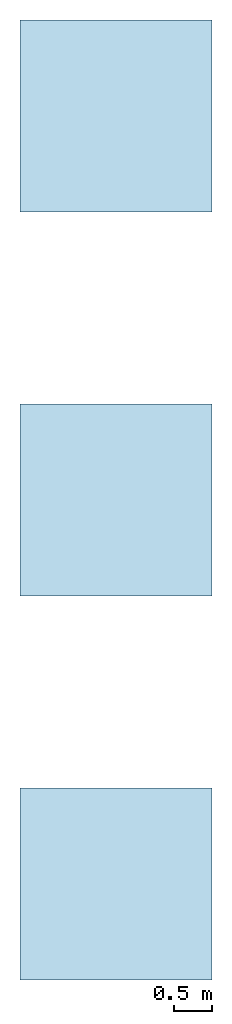
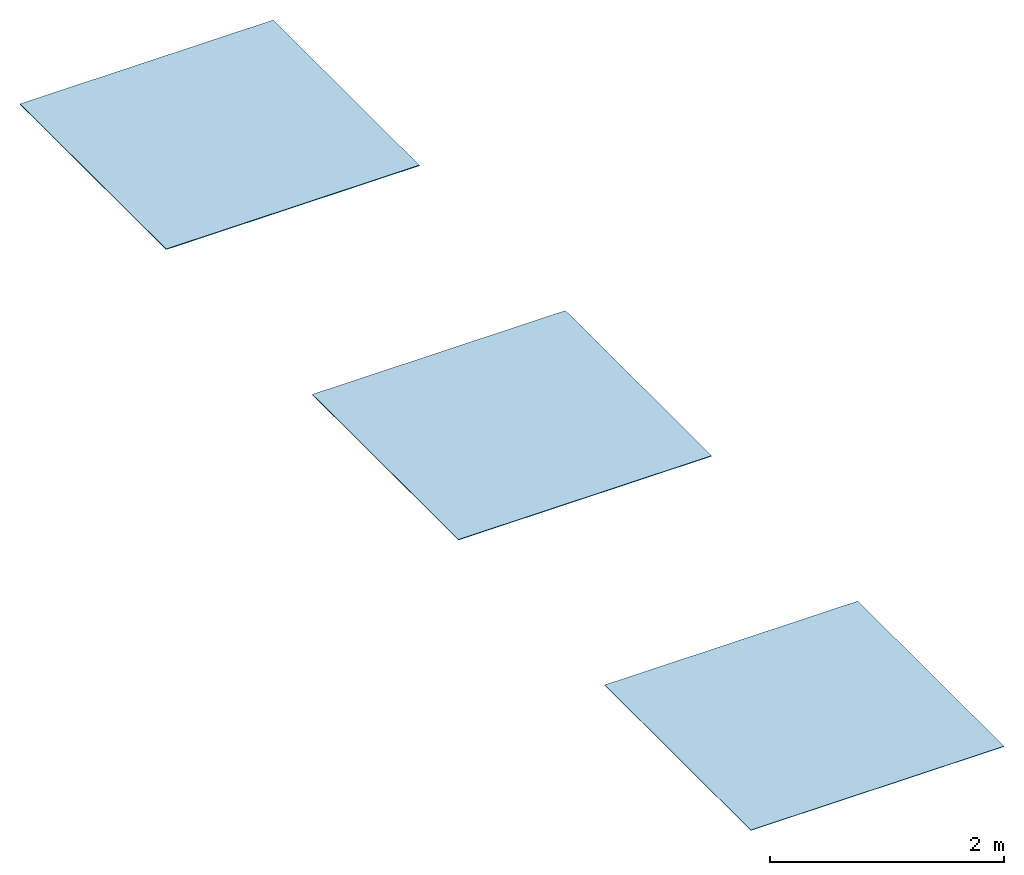
# Not in any storey: 3 slabs.
"""IFC2X3 building model written with IfcOpenShell, lengths in millimetres."""

from ifc_helpers import new_model, si_unit, frame, frame_2d, origin, origin_with_axes, origin_2d, place, context, project, spatial, rectangle, extrude, material, layer, layer_set, layer_usage, type_object, element, save


model = new_model("IFC2X3")

# Units and contexts
model_context = context("Model", 3, precision=1e-05, world=origin())
plan_context = context("Plan", 2, precision=1e-05, world=origin_2d())
ifc_project = project(units=[si_unit("LENGTHUNIT", "METRE", prefix="MILLI"), si_unit("AREAUNIT", "SQUARE_METRE"), si_unit("VOLUMEUNIT", "CUBIC_METRE"), si_unit("SOLIDANGLEUNIT", "STERADIAN"), si_unit("PLANEANGLEUNIT", "RADIAN"), si_unit("MASSUNIT", "GRAM"), si_unit("TIMEUNIT", "SECOND"), si_unit("THERMODYNAMICTEMPERATUREUNIT", "DEGREE_CELSIUS"), si_unit("LUMINOUSINTENSITYUNIT", "LUMEN")], contexts=[model_context, plan_context])

# Site, building
site_placement = place(None, frame((0.0, 0.0, 0.0), z_axis=(0.0, 1.0, 0.0), x_axis=(0.0, 0.0, 1.0)))
site = spatial("IfcSite", under=ifc_project, at=site_placement, CompositionType="ELEMENT")
building_placement = place(site_placement, frame((0.0, 0.0, 0.0), z_axis=(0.0, 1.0, 0.0), x_axis=(0.0, 0.0, 1.0)))
building = spatial("IfcBuilding", under=site, at=building_placement, Name="Default building", CompositionType="ELEMENT")

# Slabs
ifc_material_1 = material()
ifc_layer_1 = layer(ifc_material_1, 5.0, ventilated=False)
ifc_layer_set_1 = layer_set([ifc_layer_1])
ifc_layer_usage_1 = layer_usage(ifc_layer_set_1, "AXIS3", "NEGATIVE", 0.0)
slab_type_1 = type_object("IfcSlabType", PredefinedType="ROOF", material=ifc_layer_set_1)
slab_1_placement = place(None, origin())
element("IfcSlab", 1, at=slab_1_placement, inside=building, type_object=slab_type_1, material=ifc_layer_usage_1, PredefinedType="ROOF", context=model_context, shape_type="SweptSolid", body=[
    extrude(rectangle(XDim=2500.0, YDim=2500.0, at=frame_2d((1250.0, 1250.0))), origin_with_axes(), (0.0, 0.0, 1.0), 5.0),
])
ifc_material_2 = material()
ifc_layer_2 = layer(ifc_material_2, 6.5, ventilated=False)
ifc_layer_set_2 = layer_set([ifc_layer_2])
ifc_layer_usage_2 = layer_usage(ifc_layer_set_2, "AXIS3", "NEGATIVE", 0.0)
slab_type_2 = type_object("IfcSlabType", PredefinedType="ROOF", material=ifc_layer_set_2)
slab_2_placement = place(None, frame((0.0, 5000.0, 0.0)))
element("IfcSlab", 2, at=slab_2_placement, inside=building, type_object=slab_type_2, material=ifc_layer_usage_2, PredefinedType="ROOF", context=model_context, shape_type="SweptSolid", body=[
    extrude(rectangle(XDim=2500.0, YDim=2500.0, at=frame_2d((1250.0, 1250.0))), origin_with_axes(), (0.0, 0.0, 1.0), 6.5),
])
ifc_material_3 = material()
ifc_layer_3 = layer(ifc_material_3, 7.5, ventilated=False)
ifc_layer_set_3 = layer_set([ifc_layer_3])
ifc_layer_usage_3 = layer_usage(ifc_layer_set_3, "AXIS3", "NEGATIVE", 0.0)
slab_type_3 = type_object("IfcSlabType", PredefinedType="ROOF", material=ifc_layer_set_3)
slab_3_placement = place(None, frame((0.0, 10000.0, 0.0)))
element("IfcSlab", 3, at=slab_3_placement, inside=building, type_object=slab_type_3, material=ifc_layer_usage_3, PredefinedType="ROOF", context=model_context, shape_type="SweptSolid", body=[
    extrude(rectangle(XDim=2500.0, YDim=2500.0, at=frame_2d((1250.0, 1250.0))), origin_with_axes(), (0.0, 0.0, 1.0), 7.5),
])

save(model, "model.ifc")
